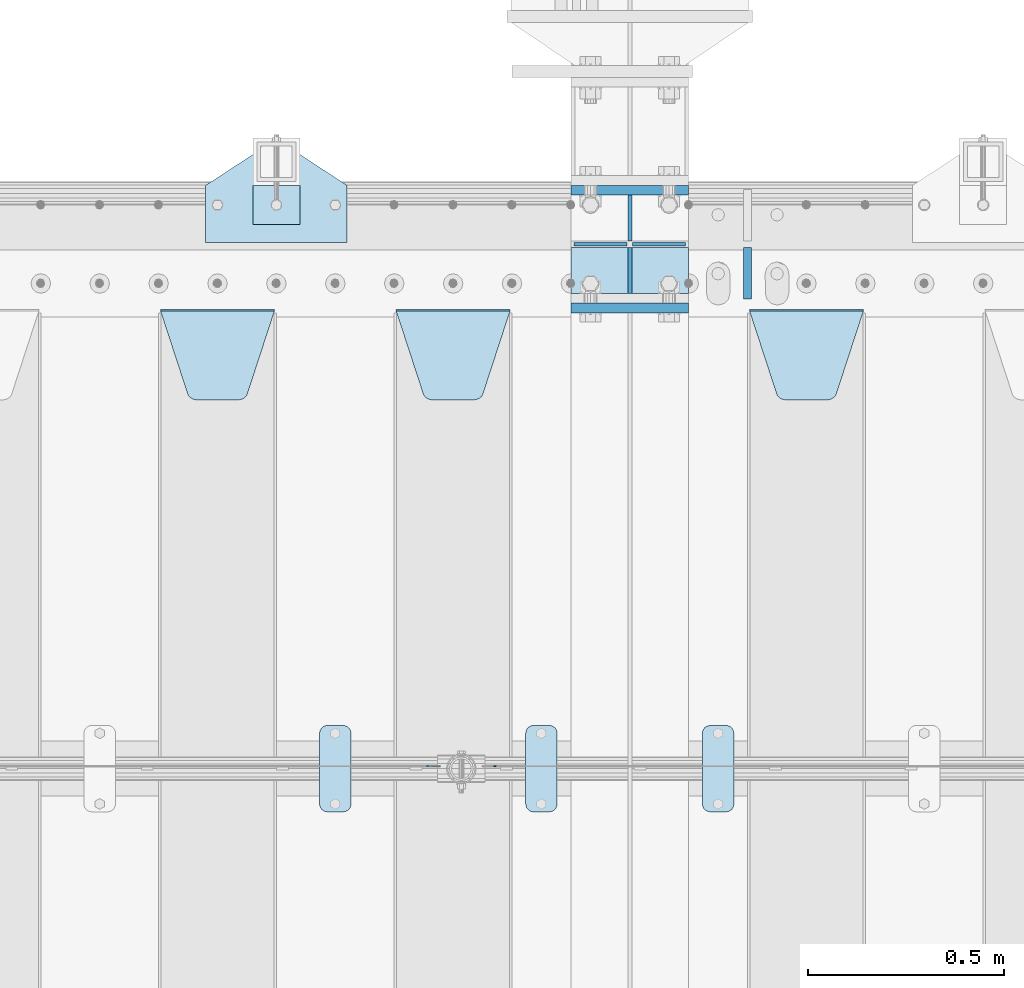
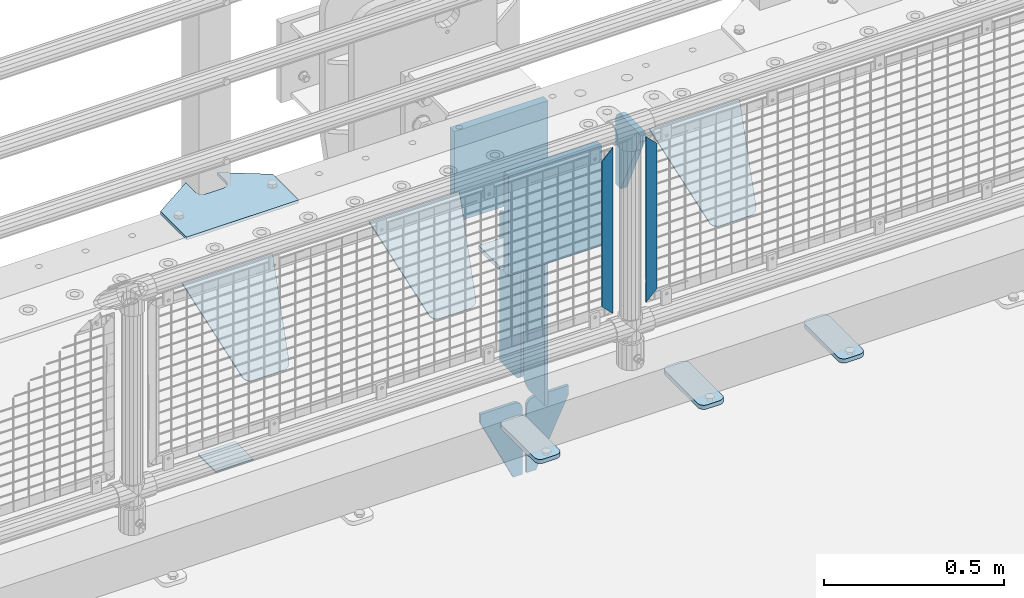
# One storey, part 220 of 247: 18 plates.
"""IFC2X3 building model written with IfcOpenShell, lengths in millimetres."""

import ifcopenshell
import ifcopenshell.guid

model = None  # the IFC model being written
_history = None  # IfcOwnerHistory: only IFC2X3 demands one
_inside = {}  # id of a spatial element -> (the spatial element, [elements in it])
_under = {}  # id of a project, library or spatial element -> (it, [spatial elements below it])
_declared = {}  # id of a project -> (the project, [libraries it declares])
_typed = {}  # id of a type object -> (the type object, [elements of that type])
_made_of = {}  # id of a material, layer set ... -> (it, [elements and type objects made of it])


def new_model(schema):
    """Start an empty IFC model of exactly this schema.

    Asked for "IFC4X3", IfcOpenShell would pick the latest addendum, in which some entities
    have other attributes; the version numbers below select the first issue.
    IFC2X3 requires an IfcOwnerHistory on every rooted entity: one is made here for all.
    """
    global model, _history
    if schema == "IFC4X3":
        model = ifcopenshell.file(schema_version=(4, 3, 0, 0))
    else:
        model = ifcopenshell.file(schema=schema)
    _inside.clear()
    _under.clear()
    _declared.clear()
    _typed.clear()
    _made_of.clear()
    _history = None
    if model.schema == "IFC2X3":
        org = make("IfcOrganization", Name="unknown")
        user = make(
            "IfcPersonAndOrganization",
            ThePerson=make("IfcPerson", FamilyName="unknown"),
            TheOrganization=org,
        )
        app = make(
            "IfcApplication",
            ApplicationDeveloper=org,
            Version="unknown",
            ApplicationFullName="unknown",
            ApplicationIdentifier="unknown",
        )
        _history = make(
            "IfcOwnerHistory",
            OwningUser=user,
            OwningApplication=app,
            ChangeAction="ADDED",
            CreationDate=0,
        )
    return model


def make(cls, **values):
    """One entity of the class cls with the attributes given. An attribute that is None is left unset."""
    return model.create_entity(
        cls, **{name: value for name, value in values.items() if value is not None}
    )


def rooted(cls, **values):
    """An entity with a GlobalId (a new one), such as an element, a storey or a relation."""
    return make(cls, GlobalId=ifcopenshell.guid.new(), OwnerHistory=_history, **values)


def si_unit(unit_type, name, prefix=None):
    """IfcSIUnit, for example si_unit("LENGTHUNIT", "METRE", prefix="MILLI")."""
    return make("IfcSIUnit", UnitType=unit_type, Prefix=prefix, Name=name)


def assignment(units):
    """IfcUnitAssignment: the units of a project."""
    return None if units is None else make("IfcUnitAssignment", Units=units)


def point(xyz):
    """IfcCartesianPoint."""
    return None if xyz is None else make("IfcCartesianPoint", Coordinates=xyz)


def direction(xyz):
    """IfcDirection."""
    return None if xyz is None else make("IfcDirection", DirectionRatios=xyz)


def frame(location, z_axis=None, x_axis=None):
    """IfcAxis2Placement3D, a coordinate frame: its origin and axes. An axis left out is left unset."""
    return make(
        "IfcAxis2Placement3D",
        Location=point(location),
        Axis=direction(z_axis),
        RefDirection=direction(x_axis),
    )


def origin_with_axes():
    """The frame at (0, 0, 0) with the z axis (0, 0, 1) and the x axis (1, 0, 0) written out."""
    return frame((0.0, 0.0, 0.0), z_axis=(0.0, 0.0, 1.0), x_axis=(1.0, 0.0, 0.0))


def place(relative_to, where):
    """IfcLocalPlacement: puts the frame where relative to a parent placement (None: the world)."""
    return make(
        "IfcLocalPlacement", PlacementRelTo=relative_to, RelativePlacement=where
    )


def context(
    kind, dimensions, precision=None, world=None, true_north=None, identifier=None
):
    """IfcGeometricRepresentationContext, for example the 3D "Model" context."""
    return make(
        "IfcGeometricRepresentationContext",
        ContextIdentifier=identifier,
        ContextType=kind,
        CoordinateSpaceDimension=dimensions,
        Precision=precision,
        WorldCoordinateSystem=world,
        TrueNorth=true_north,
    )


def subcontext(parent, identifier, kind, view, scale=None):
    """IfcGeometricRepresentationSubContext, for example "Body" below "Model"."""
    return make(
        "IfcGeometricRepresentationSubContext",
        ContextIdentifier=identifier,
        ContextType=kind,
        ParentContext=parent,
        TargetScale=scale,
        TargetView=view,
    )


def project(units=None, contexts=None):
    """IfcProject with its units and contexts."""
    return rooted(
        "IfcProject",
        Name="project",
        RepresentationContexts=contexts,
        UnitsInContext=assignment(units),
    )


def spatial(cls, under=None, at=None, **own):
    """A site, building, storey or space (cls), placed at a placement, below another one or the project."""
    s = rooted(cls, ObjectPlacement=at, **own)
    if under is not None:
        _under.setdefault(under.id(), (under, []))[1].append(s)
    return s


def faces_of(points, faces, orient=None, outer=None):
    """IfcFace entities. A face is a list of loops; a loop is a list of indices into points, from 0.

    orient and outer hold one flag for each loop. By default every Orientation is true, the
    first loop of a face is its IfcFaceOuterBound and the others are IfcFaceBound.
    """
    made = []
    for i, loops in enumerate(faces):
        bounds = []
        for j, loop in enumerate(loops):
            is_outer = j == 0 if outer is None else outer[i][j]
            bounds.append(
                make(
                    "IfcFaceOuterBound" if is_outer else "IfcFaceBound",
                    Bound=make("IfcPolyLoop", Polygon=[points[k] for k in loop]),
                    Orientation=True if orient is None else orient[i][j],
                )
            )
        made.append(make("IfcFace", Bounds=bounds))
    return made


def faceted_brep(points, faces, orient=None, outer=None, voids=None):
    """IfcFacetedBrep: a solid bounded by flat faces; with voids (closed shells), ...WithVoids."""
    shared = [point(p) for p in points]
    hull = make("IfcClosedShell", CfsFaces=faces_of(shared, faces, orient, outer))
    if voids is None:
        return make("IfcFacetedBrep", Outer=hull)
    return make(
        "IfcFacetedBrepWithVoids",
        Outer=hull,
        Voids=[
            make(cls, CfsFaces=faces_of(shared, fs, o, b)) for cls, fs, o, b in voids
        ],
    )


def shape(context_of_items, identifier, shape_type, items):
    """IfcShapeRepresentation: the items that make up one representation, for example the "Body"."""
    return make(
        "IfcShapeRepresentation",
        ContextOfItems=context_of_items,
        RepresentationIdentifier=identifier,
        RepresentationType=shape_type,
        Items=items,
    )


def material(Name=None, Category=None):
    """IfcMaterial."""
    return make("IfcMaterial", Name=Name, Category=Category)


def made_of(thing, what):
    """Note that an element or type object is made of a material, layer set ...; save() writes the relation."""
    if what is not None:
        _made_of.setdefault(what.id(), (what, []))[1].append(thing)
    return thing


def type_object(cls, material=None, **own):
    """A type object (cls), such as IfcWallType, which elements share."""
    return made_of(rooted(cls, **own), material)


def element(
    cls,
    number,
    at=None,
    inside=None,
    cuts=None,
    type_object=None,
    material=None,
    context=None,
    identifier="Body",
    shape_type=None,
    held_by="IfcProductDefinitionShape",
    body=None,
    shapes=None,
    **own,
):
    """One element of the class cls, such as IfcWall. Its Tag is "e" and its number.

    at: its placement. inside: the storey or other place that contains it. cuts: it is an
    opening in that element (IfcRelVoidsElement). A single representation is given by context,
    identifier, shape_type and body (its items); several are given by shapes. held_by: the class
    of the entity that holds the representations. save() writes the other relations.
    """
    e = rooted(cls, Tag="e%d" % number, ObjectPlacement=at, **own)
    if body is not None:
        shapes = [shape(context, identifier, shape_type, body)]
    if shapes is not None:
        e.Representation = make(held_by, Representations=shapes)
    if inside is not None:
        _inside.setdefault(inside.id(), (inside, []))[1].append(e)
    if cuts is not None:
        rooted(
            "IfcRelVoidsElement", RelatingBuildingElement=cuts, RelatedOpeningElement=e
        )
    if type_object is not None:
        _typed.setdefault(type_object.id(), (type_object, []))[1].append(e)
    return made_of(e, material)


def aggregate(whole, parts):
    """IfcRelAggregates: a whole, such as a stair, and the parts it consists of."""
    return rooted("IfcRelAggregates", RelatingObject=whole, RelatedObjects=parts)


def save(model, path):
    """Write the relations noted so far, then the file.

    IfcRelAggregates (storeys below a building ...), IfcRelContainedInSpatialStructure (elements
    in a storey), IfcRelDefinesByType, IfcRelAssociatesMaterial and IfcRelDeclares: one each for
    every whole, place, type object, material and project.
    """
    for whole, parts in _under.values():
        aggregate(whole, parts)
    for where, things in _inside.values():
        rooted(
            "IfcRelContainedInSpatialStructure",
            RelatedElements=things,
            RelatingStructure=where,
        )
    for kind, things in _typed.values():
        rooted("IfcRelDefinesByType", RelatedObjects=things, RelatingType=kind)
    for what, things in _made_of.values():
        rooted("IfcRelAssociatesMaterial", RelatedObjects=things, RelatingMaterial=what)
    for by, libraries in _declared.values():
        rooted("IfcRelDeclares", RelatingContext=by, RelatedDefinitions=libraries)
    model.write(path)


model = new_model("IFC2X3")

# Units and contexts
model_context = context("Model", 3, precision=1e-05, world=origin_with_axes())
body_context = subcontext(model_context, "Body", "Model", "MODEL_VIEW")
ifc_project = project(units=[si_unit("LENGTHUNIT", "METRE", prefix="MILLI"), si_unit("AREAUNIT", "SQUARE_METRE"), si_unit("VOLUMEUNIT", "CUBIC_METRE"), si_unit("MASSUNIT", "GRAM", prefix="KILO"), si_unit("TIMEUNIT", "SECOND"), si_unit("PLANEANGLEUNIT", "RADIAN"), si_unit("SOLIDANGLEUNIT", "STERADIAN"), si_unit("THERMODYNAMICTEMPERATUREUNIT", "DEGREE_CELSIUS"), si_unit("LUMINOUSINTENSITYUNIT", "LUMEN")], contexts=[model_context])

# Site, building, storey
site_placement = place(None, origin_with_axes())
site = spatial("IfcSite", under=ifc_project, at=site_placement, CompositionType="ELEMENT")
building_placement = place(site_placement, origin_with_axes())
building = spatial("IfcBuilding", under=site, at=building_placement, Name="Standard", CompositionType="ELEMENT")
storey_placement = place(building_placement, origin_with_axes())
storey = spatial("IfcBuildingStorey", under=building, at=storey_placement, Name="Undefined", CompositionType="ELEMENT", Elevation=0.0)

# Plates
ifc_material_1 = material(Name="STEEL/S355N")
plate_type_1 = type_object("IfcPlateType", PredefinedType="NOTDEFINED")
plate_1_placement = place(storey_placement, frame((12100.0, 8837.5, -340.000000000044), z_axis=(0.0, 0.0, 1.0), x_axis=(1.0, 0.0, 0.0)))
element("IfcPlate", 1, at=plate_1_placement, inside=storey, type_object=plate_type_1, material=ifc_material_1, context=body_context, shape_type="Brep", body=[
    faceted_brep([(0.0, -12.5, 0.0), (0.0, -12.5, 340.0), (0.0, 12.5, 340.0), (0.0, 12.5, 0.0), (300.0, -12.5, 340.0), (300.0, 12.5, 340.0), (300.0, -12.5, 0.0), (300.0, 12.5, 0.0)], [[[0, 1, 2, 3]], [[1, 4, 5, 2]], [[4, 6, 7, 5]], [[6, 0, 3, 7]], [[5, 7, 3, 2]], [[6, 4, 1, 0]]]),
])
plate_2_placement = place(storey_placement, frame((12100.0, 9137.5, -340.0), z_axis=(0.0, 0.0, 1.0), x_axis=(1.0, 0.0, 0.0)))
element("IfcPlate", 2, at=plate_2_placement, inside=storey, type_object=plate_type_1, material=ifc_material_1, context=body_context, shape_type="Brep", body=[
    faceted_brep([(0.0, -12.5, 0.0), (0.0, -12.5, 310.0), (0.0, 12.5, 310.0), (0.0, 12.5, 0.0), (300.0, -12.5, 310.0), (300.0, 12.5, 310.0), (300.0, -12.5, 0.0), (300.0, 12.5, 0.0)], [[[0, 1, 2, 3]], [[1, 4, 5, 2]], [[4, 6, 7, 5]], [[6, 0, 3, 7]], [[5, 7, 3, 2]], [[6, 4, 1, 0]]]),
])
plate_type_2 = type_object("IfcPlateType", PredefinedType="NOTDEFINED")
plate_3_placement = place(storey_placement, frame((12100.0, 8992.0, -343.0), z_axis=(0.0, -0.999999999999548, -9.5100000000016e-07), x_axis=(1.0, 0.0, 0.0)))
element("IfcPlate", 3, at=plate_3_placement, inside=storey, type_object=plate_type_2, material=ifc_material_1, context=body_context, shape_type="Brep", body=[
    faceted_brep([(0.0, -7.0, 0.0), (0.0, -7.0, 117.0), (0.0, 7.0, 117.0), (0.0, 7.0, 0.0), (300.0, -7.0, 117.0), (300.0, 7.0, 117.0), (300.0, -7.0, 0.0), (300.0, 7.0, 0.0)], [[[0, 1, 2, 3]], [[1, 4, 5, 2]], [[4, 6, 7, 5]], [[6, 0, 3, 7]], [[5, 7, 3, 2]], [[6, 4, 1, 0]]]),
])
plate_type_3 = type_object("IfcPlateType", PredefinedType="NOTDEFINED")
for number, where, z_axis, x_axis in (
    (4, (12250.0, 8992.0, -350.0), (0.0, 0.0, -1.0), (0.0, -0.999999999999548, -9.5100000000016e-07)),
    (5, (12250.0, 9008.0, -350.0), (0.0, 0.0, -1.0), (0.0, 1.0, 0.0)),
):
    element("IfcPlate", number, at=place(storey_placement, frame(where, z_axis=z_axis, x_axis=x_axis)), inside=storey, type_object=plate_type_3, material=ifc_material_1, context=body_context, shape_type="Brep", body=[
        faceted_brep([(9.04219632502645e-09, -5.00000000143385, -2.89173840428703e-09), (0.0, -5.0, 480.0), (0.0, 5.0, 480.0), (7.66340235713869e-09, 4.99999999856618, -2.89173840428703e-09), (0.455767409633609, -5.0, 485.209445330008), (0.455767409633609, 5.0, 485.209445330008), (1.80922137642256, -5.0, 490.26060429977), (1.80922137642256, 5.0, 490.26060429977), (4.01923788646673, -5.0, 495.0), (4.01923788646673, 5.0, 495.0), (7.01866670643085, -5.0, 499.283628290596), (7.01866670643085, 5.0, 499.283628290596), (10.716371709404, -5.0, 502.981333293569), (10.716371709404, 5.0, 502.981333293569), (15.0, -5.0, 505.980762113533), (15.0, 5.0, 505.980762113533), (19.73939570023, -5.0, 508.190778623577), (19.73939570023, 5.0, 508.190778623577), (24.7905546699922, -5.0, 509.544232590366), (24.7905546699922, 5.0, 509.544232590366), (30.0, -5.0, 510.0), (30.0, 5.0, 510.0), (117.0, -5.0, 510.0), (117.0, 5.0, 510.0), (117.0, -5.0, 0.0), (117.0, 5.0, 0.0)], [[[0, 1, 2, 3]], [[1, 4, 5, 2]], [[4, 6, 7, 5]], [[6, 8, 9, 7]], [[8, 10, 11, 9]], [[10, 12, 13, 11]], [[12, 14, 15, 13]], [[14, 16, 17, 15]], [[16, 18, 19, 17]], [[18, 20, 21, 19]], [[20, 22, 23, 21]], [[22, 24, 25, 23]], [[24, 0, 3, 25]], [[5, 7, 9, 11, 13, 15, 17, 19, 21, 23, 25, 3, 2]], [[24, 22, 20, 18, 16, 14, 12, 10, 8, 6, 4, 1, 0]]]),
    ])
ifc_material_2 = material(Name="STEEL/S355J2")
plate_type_4 = type_object("IfcPlateType", PredefinedType="NOTDEFINED")
plate_4_placement = place(storey_placement, frame((11985.0, 7774.5, 21.0199999999977), z_axis=(1.0, 0.0, 0.0), x_axis=(0.0, -0.999999999999548, -9.5100000000016e-07)))
element("IfcPlate", 6, at=plate_4_placement, inside=storey, type_object=plate_type_4, material=ifc_material_2, context=body_context, shape_type="Brep", body=[
    faceted_brep([(0.0, -7.0, 20.0), (0.0, -7.0, 60.0), (0.0, 7.0, 60.0), (0.0, 7.0, 20.0), (0.384294391935327, -7.0, 63.9018064403226), (0.384294391935327, 7.0, 63.9018064403226), (1.52240934977453, -7.0, 67.6536686473009), (1.52240934977453, 7.0, 67.6536686473009), (3.37060775394912, -7.0, 71.1114046603925), (3.37060775394912, 7.0, 71.1114046603925), (5.85786437626939, -7.0, 74.1421356237315), (5.85786437626939, 7.0, 74.1421356237315), (8.8885953396084, -7.0, 76.6293922460518), (8.8885953396084, 7.0, 76.6293922460518), (12.3463313526981, -7.0, 78.4775906502255), (12.3463313526981, 7.0, 78.4775906502255), (16.0981935596774, -7.0, 79.6157056080647), (16.0981935596774, 7.0, 79.6157056080647), (20.0, -7.0, 80.0), (20.0, 7.0, 80.0), (200.0, -7.0, 80.0), (200.0, 7.0, 80.0), (203.901806440323, -7.0, 79.6157056080647), (203.901806440323, 7.0, 79.6157056080647), (207.653668647302, -7.0, 78.4775906502255), (207.653668647302, 7.0, 78.4775906502255), (211.111404660392, -7.0, 76.6293922460518), (211.111404660392, 7.0, 76.6293922460518), (214.142135623731, -7.0, 74.1421356237315), (214.142135623731, 7.0, 74.1421356237315), (216.629392246051, -7.0, 71.1114046603925), (216.629392246051, 7.0, 71.1114046603925), (218.477590650225, -7.0, 67.6536686473009), (218.477590650225, 7.0, 67.6536686473009), (219.615705608065, -7.0, 63.9018064403226), (219.615705608065, 7.0, 63.9018064403226), (220.0, -7.0, 60.0), (220.0, 7.0, 60.0), (220.0, -7.0, 20.0), (220.0, 7.0, 20.0), (219.615705608065, -7.0, 16.0981935596774), (219.615705608065, 7.0, 16.0981935596774), (218.477590650225, -7.0, 12.3463313526991), (218.477590650225, 7.0, 12.3463313526991), (216.629392246051, -7.0, 8.88859533960749), (216.629392246051, 7.0, 8.88859533960749), (214.142135623731, -7.0, 5.85786437626848), (214.142135623731, 7.0, 5.85786437626848), (211.111404660392, -7.0, 3.37060775394821), (211.111404660392, 7.0, 3.37060775394821), (207.653668647302, -7.0, 1.52240934977453), (207.653668647302, 7.0, 1.52240934977453), (203.901806440323, -7.0, 0.384294391935327), (203.901806440323, 7.0, 0.384294391935327), (200.0, -7.0, 0.0), (200.0, 7.0, 0.0), (20.0, -7.0, 0.0), (20.0, 7.0, 0.0), (16.0981935596774, -7.0, 0.384294391935327), (16.0981935596774, 7.0, 0.384294391935327), (12.3463313526981, -7.0, 1.52240934977453), (12.3463313526981, 7.0, 1.52240934977453), (8.8885953396084, -7.0, 3.37060775394821), (8.8885953396084, 7.0, 3.37060775394821), (5.85786437626939, -7.0, 5.85786437626848), (5.85786437626939, 7.0, 5.85786437626848), (3.37060775394912, -7.0, 8.88859533960749), (3.37060775394912, 7.0, 8.88859533960749), (1.52240934977453, -7.0, 12.3463313526991), (1.52240934977453, 7.0, 12.3463313526991), (0.384294391935327, -7.0, 16.0981935596774), (0.384294391935327, 7.0, 16.0981935596774)], [[[0, 1, 2, 3]], [[1, 4, 5, 2]], [[4, 6, 7, 5]], [[6, 8, 9, 7]], [[8, 10, 11, 9]], [[10, 12, 13, 11]], [[12, 14, 15, 13]], [[14, 16, 17, 15]], [[16, 18, 19, 17]], [[18, 20, 21, 19]], [[20, 22, 23, 21]], [[22, 24, 25, 23]], [[24, 26, 27, 25]], [[26, 28, 29, 27]], [[28, 30, 31, 29]], [[30, 32, 33, 31]], [[32, 34, 35, 33]], [[34, 36, 37, 35]], [[36, 38, 39, 37]], [[38, 40, 41, 39]], [[40, 42, 43, 41]], [[42, 44, 45, 43]], [[44, 46, 47, 45]], [[46, 48, 49, 47]], [[48, 50, 51, 49]], [[50, 52, 53, 51]], [[52, 54, 55, 53]], [[54, 56, 57, 55]], [[56, 58, 59, 57]], [[58, 60, 61, 59]], [[60, 62, 63, 61]], [[62, 64, 65, 63]], [[64, 66, 67, 65]], [[66, 68, 69, 67]], [[68, 70, 71, 69]], [[70, 0, 3, 71]], [[5, 7, 9, 11, 13, 15, 17, 19, 21, 23, 25, 27, 29, 31, 33, 35, 37, 39, 41, 43, 45, 47, 49, 51, 53, 55, 57, 59, 61, 63, 65, 67, 69, 71, 3, 2]], [[70, 68, 66, 64, 62, 60, 58, 56, 54, 52, 50, 48, 46, 44, 42, 40, 38, 36, 34, 32, 30, 28, 26, 24, 22, 20, 18, 16, 14, 12, 10, 8, 6, 4, 1, 0]]]),
])
plate_5_placement = place(storey_placement, frame((11460.0, 7774.5, 21.0199999999977), z_axis=(1.0, 0.0, 0.0), x_axis=(0.0, -0.999999999999548, -9.5100000000016e-07)))
element("IfcPlate", 7, at=plate_5_placement, inside=storey, type_object=plate_type_4, material=ifc_material_2, context=body_context, shape_type="Brep", body=[
    faceted_brep([(0.0, -7.0, 20.0), (0.0, -7.0, 60.0), (0.0, 7.0, 60.0), (0.0, 7.0, 20.0), (0.384294391935327, -7.0, 63.9018064403226), (0.384294391935327, 7.0, 63.9018064403226), (1.52240934977453, -7.0, 67.6536686473009), (1.52240934977453, 7.0, 67.6536686473009), (3.37060775394912, -7.0, 71.1114046603925), (3.37060775394912, 7.0, 71.1114046603925), (5.85786437626939, -7.0, 74.1421356237315), (5.85786437626939, 7.0, 74.1421356237315), (8.8885953396084, -7.0, 76.6293922460518), (8.8885953396084, 7.0, 76.6293922460518), (12.3463313526981, -7.0, 78.4775906502255), (12.3463313526981, 7.0, 78.4775906502255), (16.0981935596774, -7.0, 79.6157056080647), (16.0981935596774, 7.0, 79.6157056080647), (20.0, -7.0, 80.0), (20.0, 7.0, 80.0), (200.0, -7.0, 80.0), (200.0, 7.0, 80.0), (203.901806440323, -7.0, 79.6157056080647), (203.901806440323, 7.0, 79.6157056080647), (207.653668647302, -7.0, 78.4775906502255), (207.653668647302, 7.0, 78.4775906502255), (211.111404660392, -7.0, 76.6293922460518), (211.111404660392, 7.0, 76.6293922460518), (214.142135623731, -7.0, 74.1421356237315), (214.142135623731, 7.0, 74.1421356237315), (216.629392246051, -7.0, 71.1114046603925), (216.629392246051, 7.0, 71.1114046603925), (218.477590650225, -7.0, 67.6536686473009), (218.477590650225, 7.0, 67.6536686473009), (219.615705608065, -7.0, 63.9018064403226), (219.615705608065, 7.0, 63.9018064403226), (220.0, -7.0, 60.0), (220.0, 7.0, 60.0), (220.0, -7.0, 20.0), (220.0, 7.0, 20.0), (219.615705608065, -7.0, 16.0981935596774), (219.615705608065, 7.0, 16.0981935596774), (218.477590650225, -7.0, 12.3463313526991), (218.477590650225, 7.0, 12.3463313526991), (216.629392246051, -7.0, 8.88859533960749), (216.629392246051, 7.0, 8.88859533960749), (214.142135623731, -7.0, 5.85786437626848), (214.142135623731, 7.0, 5.85786437626848), (211.111404660392, -7.0, 3.37060775394821), (211.111404660392, 7.0, 3.37060775394821), (207.653668647302, -7.0, 1.52240934977453), (207.653668647302, 7.0, 1.52240934977453), (203.901806440323, -7.0, 0.384294391935327), (203.901806440323, 7.0, 0.384294391935327), (200.0, -7.0, 0.0), (200.0, 7.0, 0.0), (20.0, -7.0, 0.0), (20.0, 7.0, 0.0), (16.0981935596774, -7.0, 0.384294391935327), (16.0981935596774, 7.0, 0.384294391935327), (12.3463313526981, -7.0, 1.52240934977453), (12.3463313526981, 7.0, 1.52240934977453), (8.8885953396084, -7.0, 3.37060775394821), (8.8885953396084, 7.0, 3.37060775394821), (5.85786437626939, -7.0, 5.85786437626848), (5.85786437626939, 7.0, 5.85786437626848), (3.37060775394912, -7.0, 8.88859533960749), (3.37060775394912, 7.0, 8.88859533960749), (1.52240934977453, -7.0, 12.3463313526991), (1.52240934977453, 7.0, 12.3463313526991), (0.384294391935327, -7.0, 16.0981935596774), (0.384294391935327, 7.0, 16.0981935596774)], [[[0, 1, 2, 3]], [[1, 4, 5, 2]], [[4, 6, 7, 5]], [[6, 8, 9, 7]], [[8, 10, 11, 9]], [[10, 12, 13, 11]], [[12, 14, 15, 13]], [[14, 16, 17, 15]], [[16, 18, 19, 17]], [[18, 20, 21, 19]], [[20, 22, 23, 21]], [[22, 24, 25, 23]], [[24, 26, 27, 25]], [[26, 28, 29, 27]], [[28, 30, 31, 29]], [[30, 32, 33, 31]], [[32, 34, 35, 33]], [[34, 36, 37, 35]], [[36, 38, 39, 37]], [[38, 40, 41, 39]], [[40, 42, 43, 41]], [[42, 44, 45, 43]], [[44, 46, 47, 45]], [[46, 48, 49, 47]], [[48, 50, 51, 49]], [[50, 52, 53, 51]], [[52, 54, 55, 53]], [[54, 56, 57, 55]], [[56, 58, 59, 57]], [[58, 60, 61, 59]], [[60, 62, 63, 61]], [[62, 64, 65, 63]], [[64, 66, 67, 65]], [[66, 68, 69, 67]], [[68, 70, 71, 69]], [[70, 0, 3, 71]], [[5, 7, 9, 11, 13, 15, 17, 19, 21, 23, 25, 27, 29, 31, 33, 35, 37, 39, 41, 43, 45, 47, 49, 51, 53, 55, 57, 59, 61, 63, 65, 67, 69, 71, 3, 2]], [[70, 68, 66, 64, 62, 60, 58, 56, 54, 52, 50, 48, 46, 44, 42, 40, 38, 36, 34, 32, 30, 28, 26, 24, 22, 20, 18, 16, 14, 12, 10, 8, 6, 4, 1, 0]]]),
])
plate_6_placement = place(storey_placement, frame((12435.0, 7774.5, 21.0199999999977), z_axis=(1.0, 0.0, 0.0), x_axis=(0.0, -0.999999999999548, -9.5100000000016e-07)))
element("IfcPlate", 8, at=plate_6_placement, inside=storey, type_object=plate_type_4, material=ifc_material_2, context=body_context, shape_type="Brep", body=[
    faceted_brep([(0.0, -7.0, 20.0), (0.0, -7.0, 60.0), (0.0, 7.0, 60.0), (0.0, 7.0, 20.0), (0.384294391935327, -7.0, 63.9018064403226), (0.384294391935327, 7.0, 63.9018064403226), (1.52240934977453, -7.0, 67.6536686473009), (1.52240934977453, 7.0, 67.6536686473009), (3.37060775394912, -7.0, 71.1114046603925), (3.37060775394912, 7.0, 71.1114046603925), (5.85786437626939, -7.0, 74.1421356237315), (5.85786437626939, 7.0, 74.1421356237315), (8.8885953396084, -7.0, 76.6293922460518), (8.8885953396084, 7.0, 76.6293922460518), (12.3463313526981, -7.0, 78.4775906502255), (12.3463313526981, 7.0, 78.4775906502255), (16.0981935596774, -7.0, 79.6157056080647), (16.0981935596774, 7.0, 79.6157056080647), (20.0, -7.0, 80.0), (20.0, 7.0, 80.0), (200.0, -7.0, 80.0), (200.0, 7.0, 80.0), (203.901806440323, -7.0, 79.6157056080647), (203.901806440323, 7.0, 79.6157056080647), (207.653668647302, -7.0, 78.4775906502255), (207.653668647302, 7.0, 78.4775906502255), (211.111404660392, -7.0, 76.6293922460518), (211.111404660392, 7.0, 76.6293922460518), (214.142135623731, -7.0, 74.1421356237315), (214.142135623731, 7.0, 74.1421356237315), (216.629392246051, -7.0, 71.1114046603925), (216.629392246051, 7.0, 71.1114046603925), (218.477590650225, -7.0, 67.6536686473009), (218.477590650225, 7.0, 67.6536686473009), (219.615705608065, -7.0, 63.9018064403226), (219.615705608065, 7.0, 63.9018064403226), (220.0, -7.0, 60.0), (220.0, 7.0, 60.0), (220.0, -7.0, 20.0), (220.0, 7.0, 20.0), (219.615705608065, -7.0, 16.0981935596774), (219.615705608065, 7.0, 16.0981935596774), (218.477590650225, -7.0, 12.3463313526991), (218.477590650225, 7.0, 12.3463313526991), (216.629392246051, -7.0, 8.88859533960749), (216.629392246051, 7.0, 8.88859533960749), (214.142135623731, -7.0, 5.85786437626848), (214.142135623731, 7.0, 5.85786437626848), (211.111404660392, -7.0, 3.37060775394821), (211.111404660392, 7.0, 3.37060775394821), (207.653668647302, -7.0, 1.52240934977453), (207.653668647302, 7.0, 1.52240934977453), (203.901806440323, -7.0, 0.384294391935327), (203.901806440323, 7.0, 0.384294391935327), (200.0, -7.0, 0.0), (200.0, 7.0, 0.0), (20.0, -7.0, 0.0), (20.0, 7.0, 0.0), (16.0981935596774, -7.0, 0.384294391935327), (16.0981935596774, 7.0, 0.384294391935327), (12.3463313526981, -7.0, 1.52240934977453), (12.3463313526981, 7.0, 1.52240934977453), (8.8885953396084, -7.0, 3.37060775394821), (8.8885953396084, 7.0, 3.37060775394821), (5.85786437626939, -7.0, 5.85786437626848), (5.85786437626939, 7.0, 5.85786437626848), (3.37060775394912, -7.0, 8.88859533960749), (3.37060775394912, 7.0, 8.88859533960749), (1.52240934977453, -7.0, 12.3463313526991), (1.52240934977453, 7.0, 12.3463313526991), (0.384294391935327, -7.0, 16.0981935596774), (0.384294391935327, 7.0, 16.0981935596774)], [[[0, 1, 2, 3]], [[1, 4, 5, 2]], [[4, 6, 7, 5]], [[6, 8, 9, 7]], [[8, 10, 11, 9]], [[10, 12, 13, 11]], [[12, 14, 15, 13]], [[14, 16, 17, 15]], [[16, 18, 19, 17]], [[18, 20, 21, 19]], [[20, 22, 23, 21]], [[22, 24, 25, 23]], [[24, 26, 27, 25]], [[26, 28, 29, 27]], [[28, 30, 31, 29]], [[30, 32, 33, 31]], [[32, 34, 35, 33]], [[34, 36, 37, 35]], [[36, 38, 39, 37]], [[38, 40, 41, 39]], [[40, 42, 43, 41]], [[42, 44, 45, 43]], [[44, 46, 47, 45]], [[46, 48, 49, 47]], [[48, 50, 51, 49]], [[50, 52, 53, 51]], [[52, 54, 55, 53]], [[54, 56, 57, 55]], [[56, 58, 59, 57]], [[58, 60, 61, 59]], [[60, 62, 63, 61]], [[62, 64, 65, 63]], [[64, 66, 67, 65]], [[66, 68, 69, 67]], [[68, 70, 71, 69]], [[70, 0, 3, 71]], [[5, 7, 9, 11, 13, 15, 17, 19, 21, 23, 25, 27, 29, 31, 33, 35, 37, 39, 41, 43, 45, 47, 49, 51, 53, 55, 57, 59, 61, 63, 65, 67, 69, 71, 3, 2]], [[70, 68, 66, 64, 62, 60, 58, 56, 54, 52, 50, 48, 46, 44, 42, 40, 38, 36, 34, 32, 30, 28, 26, 24, 22, 20, 18, 16, 14, 12, 10, 8, 6, 4, 1, 0]]]),
])
plate_type_5 = type_object("IfcPlateType", PredefinedType="NOTDEFINED")
for number, where, z_axis, x_axis in (
    (9, (12243.5000000106, 8999.99999998465, -915.000018222568), (0.0, 0.0, -1.0), (-1.0, 0.0, 0.0)),
    (10, (12256.5000000107, 8999.99999998464, -915.000018222568), (0.0, 0.0, -1.0), (1.0, 0.0, 0.0)),
):
    element("IfcPlate", number, at=place(storey_placement, frame(where, z_axis=z_axis, x_axis=x_axis)), inside=storey, type_object=plate_type_5, material=ifc_material_1, context=body_context, shape_type="Brep", body=[
        faceted_brep([(0.0, -5.0, 27.0), (0.0, -5.0, 250.0), (0.0, 5.0, 250.0), (0.0, 5.0, 27.0), (30.0, -5.0, 250.0), (30.0, 5.0, 250.0), (135.0, -5.0, 30.0), (135.0, 5.0, 30.0), (135.0, -5.0, 0.0), (135.0, 5.0, 0.0), (27.0, -5.0, 0.0), (27.0, 5.0, 0.0), (22.3114992029932, -5.0, 0.410190668670339), (22.3114992029932, 5.0, 0.410190668670339), (17.7654561302061, -5.0, 1.62829923878041), (17.7654561302061, 5.0, 1.62829923878041), (13.5, -5.0, 3.61731409782021), (13.5, 5.0, 3.61731409782021), (9.64473453846404, -5.0, 6.31680003578765), (9.64473453846404, 5.0, 6.31680003578765), (6.31680003578731, -5.0, 9.64473453846347), (6.31680003578731, 5.0, 9.64473453846347), (3.61731409782078, -5.0, 13.5), (3.61731409782078, 5.0, 13.5), (1.62829923878053, -5.0, 17.765456130207), (1.62829923878053, 5.0, 17.765456130207), (0.410190668670111, -5.0, 22.3114992029929), (0.410190668670111, 5.0, 22.3114992029929)], [[[0, 1, 2, 3]], [[1, 4, 5, 2]], [[4, 6, 7, 5]], [[6, 8, 9, 7]], [[8, 10, 11, 9]], [[10, 12, 13, 11]], [[12, 14, 15, 13]], [[14, 16, 17, 15]], [[16, 18, 19, 17]], [[18, 20, 21, 19]], [[20, 22, 23, 21]], [[22, 24, 25, 23]], [[24, 26, 27, 25]], [[26, 0, 3, 27]], [[5, 7, 9, 11, 13, 15, 17, 19, 21, 23, 25, 27, 3, 2]], [[26, 24, 22, 20, 18, 16, 14, 12, 10, 8, 6, 4, 1, 0]]]),
    ])
plate_type_6 = type_object("IfcPlateType", PredefinedType="NOTDEFINED")
plate_7_placement = place(storey_placement, frame((12555.0, 8831.76776695594, -1.767766952965), z_axis=(0.0, -0.707106781186548, -0.707106781186547), x_axis=(1.0, 0.0, 0.0)))
element("IfcPlate", 11, at=plate_7_placement, inside=storey, type_object=plate_type_6, material=ifc_material_1, context=body_context, shape_type="Brep", body=[
    faceted_brep([(0.0, -2.49999999999909, 0.0), (69.345504679477, -2.5, 300.17173142483), (69.345504679477, 2.50000000000091, 300.171731424831), (0.0, 2.5, -9.09494701772928e-13), (70.9274061199576, -2.5, 304.897442415399), (70.9274061199576, 2.50000000000091, 304.8974424154), (73.3818627772307, -2.49999999999909, 309.234538108527), (73.3818627772307, 2.5, 309.234538108526), (76.6187032999551, -2.5, 313.023683126102), (76.6187032999551, 2.50000000000091, 313.023683126102), (80.5190132704993, -2.49999999999909, 316.125672595371), (80.5190132704993, 2.50000000000091, 316.125672595372), (84.9395038596849, -2.49999999999909, 318.426546230476), (84.9395038596849, 2.5, 318.426546230475), (89.7177759439219, -2.5, 319.841774983274), (89.7177759439219, 2.50000000000091, 319.841774983275), (94.678286292652, -2.5, 320.319366455077), (94.678286292652, 2.50000000000091, 320.319366455077), (195.321713707348, -2.5, 320.319366455077), (195.321713707348, 2.50000000000091, 320.319366455077), (200.282224056078, -2.5, 319.841774983274), (200.282224056078, 2.50000000000091, 319.841774983275), (205.060496140315, -2.5, 318.426546230475), (205.060496140315, 2.5, 318.426546230474), (209.480986729501, -2.49999999999818, 316.12567259537), (209.480986729501, 2.50000000000091, 316.12567259537), (213.381296700045, -2.5, 313.023683126101), (213.381296700045, 2.50000000000091, 313.023683126101), (216.618137222769, -2.5, 309.234538108525), (216.618137222769, 2.5, 309.234538108525), (219.072593880042, -2.49999999999909, 304.897442415398), (219.072593880042, 2.5, 304.897442415398), (220.654495320523, -2.5, 300.17173142483), (220.654495320523, 2.50000000000091, 300.171731424831), (290.0, -2.49999999999909, 0.0), (290.0, 2.5, -9.09494701772928e-13)], [[[0, 1, 2, 3]], [[1, 4, 5, 2]], [[4, 6, 7, 5]], [[6, 8, 9, 7]], [[8, 10, 11, 9]], [[10, 12, 13, 11]], [[12, 14, 15, 13]], [[14, 16, 17, 15]], [[16, 18, 19, 17]], [[18, 20, 21, 19]], [[20, 22, 23, 21]], [[22, 24, 25, 23]], [[24, 26, 27, 25]], [[26, 28, 29, 27]], [[28, 30, 31, 29]], [[30, 32, 33, 31]], [[32, 34, 35, 33]], [[34, 0, 3, 35]], [[5, 7, 9, 11, 13, 15, 17, 19, 21, 23, 25, 27, 29, 31, 33, 35, 3, 2]], [[34, 32, 30, 28, 26, 24, 22, 20, 18, 16, 14, 12, 10, 8, 6, 4, 1, 0]]]),
])
plate_8_placement = place(storey_placement, frame((11655.0, 8831.76776695594, -1.767766952965), z_axis=(0.0, -0.707106781186548, -0.707106781186547), x_axis=(1.0, 0.0, 0.0)))
element("IfcPlate", 12, at=plate_8_placement, inside=storey, type_object=plate_type_6, material=ifc_material_1, context=body_context, shape_type="Brep", body=[
    faceted_brep([(0.0, -2.49999999999909, 0.0), (69.345504679477, -2.5, 300.17173142483), (69.345504679477, 2.50000000000091, 300.171731424831), (0.0, 2.5, -9.09494701772928e-13), (70.9274061199576, -2.5, 304.897442415399), (70.9274061199576, 2.50000000000091, 304.8974424154), (73.3818627772307, -2.49999999999909, 309.234538108527), (73.3818627772307, 2.5, 309.234538108526), (76.6187032999551, -2.5, 313.023683126102), (76.6187032999551, 2.50000000000091, 313.023683126102), (80.5190132704993, -2.49999999999909, 316.125672595371), (80.5190132704993, 2.50000000000091, 316.125672595372), (84.9395038596849, -2.49999999999909, 318.426546230476), (84.9395038596849, 2.5, 318.426546230475), (89.7177759439219, -2.5, 319.841774983274), (89.7177759439219, 2.50000000000091, 319.841774983275), (94.678286292652, -2.5, 320.319366455077), (94.678286292652, 2.50000000000091, 320.319366455077), (195.321713707348, -2.5, 320.319366455077), (195.321713707348, 2.50000000000091, 320.319366455077), (200.282224056078, -2.5, 319.841774983274), (200.282224056078, 2.50000000000091, 319.841774983275), (205.060496140315, -2.5, 318.426546230475), (205.060496140315, 2.5, 318.426546230474), (209.480986729501, -2.49999999999818, 316.12567259537), (209.480986729501, 2.50000000000091, 316.12567259537), (213.381296700045, -2.5, 313.023683126101), (213.381296700045, 2.50000000000091, 313.023683126101), (216.618137222769, -2.5, 309.234538108525), (216.618137222769, 2.5, 309.234538108525), (219.072593880042, -2.49999999999909, 304.897442415398), (219.072593880042, 2.5, 304.897442415398), (220.654495320523, -2.5, 300.17173142483), (220.654495320523, 2.50000000000091, 300.171731424831), (290.0, -2.49999999999909, 0.0), (290.0, 2.5, -9.09494701772928e-13)], [[[0, 1, 2, 3]], [[1, 4, 5, 2]], [[4, 6, 7, 5]], [[6, 8, 9, 7]], [[8, 10, 11, 9]], [[10, 12, 13, 11]], [[12, 14, 15, 13]], [[14, 16, 17, 15]], [[16, 18, 19, 17]], [[18, 20, 21, 19]], [[20, 22, 23, 21]], [[22, 24, 25, 23]], [[24, 26, 27, 25]], [[26, 28, 29, 27]], [[28, 30, 31, 29]], [[30, 32, 33, 31]], [[32, 34, 35, 33]], [[34, 0, 3, 35]], [[5, 7, 9, 11, 13, 15, 17, 19, 21, 23, 25, 27, 29, 31, 33, 35, 3, 2]], [[34, 32, 30, 28, 26, 24, 22, 20, 18, 16, 14, 12, 10, 8, 6, 4, 1, 0]]]),
])
plate_9_placement = place(storey_placement, frame((11055.0, 8831.76776695594, -1.767766952965), z_axis=(0.0, -0.707106781186548, -0.707106781186547), x_axis=(1.0, 0.0, 0.0)))
element("IfcPlate", 13, at=plate_9_placement, inside=storey, type_object=plate_type_6, material=ifc_material_1, context=body_context, shape_type="Brep", body=[
    faceted_brep([(0.0, -2.49999999999909, 0.0), (69.345504679477, -2.5, 300.17173142483), (69.345504679477, 2.50000000000091, 300.171731424831), (0.0, 2.5, -9.09494701772928e-13), (70.9274061199576, -2.5, 304.897442415399), (70.9274061199576, 2.50000000000091, 304.8974424154), (73.3818627772307, -2.49999999999909, 309.234538108527), (73.3818627772307, 2.5, 309.234538108526), (76.6187032999551, -2.5, 313.023683126102), (76.6187032999551, 2.50000000000091, 313.023683126102), (80.5190132704993, -2.49999999999909, 316.125672595371), (80.5190132704993, 2.50000000000091, 316.125672595372), (84.9395038596849, -2.49999999999909, 318.426546230476), (84.9395038596849, 2.5, 318.426546230475), (89.7177759439219, -2.5, 319.841774983274), (89.7177759439219, 2.50000000000091, 319.841774983275), (94.678286292652, -2.5, 320.319366455077), (94.678286292652, 2.50000000000091, 320.319366455077), (195.321713707348, -2.5, 320.319366455077), (195.321713707348, 2.50000000000091, 320.319366455077), (200.282224056078, -2.5, 319.841774983274), (200.282224056078, 2.50000000000091, 319.841774983275), (205.060496140315, -2.5, 318.426546230475), (205.060496140315, 2.5, 318.426546230474), (209.480986729501, -2.49999999999818, 316.12567259537), (209.480986729501, 2.50000000000091, 316.12567259537), (213.381296700045, -2.5, 313.023683126101), (213.381296700045, 2.50000000000091, 313.023683126101), (216.618137222769, -2.5, 309.234538108525), (216.618137222769, 2.5, 309.234538108525), (219.072593880042, -2.49999999999909, 304.897442415398), (219.072593880042, 2.5, 304.897442415398), (220.654495320523, -2.5, 300.17173142483), (220.654495320523, 2.50000000000091, 300.171731424831), (290.0, -2.49999999999909, 0.0), (290.0, 2.5, -9.09494701772928e-13)], [[[0, 1, 2, 3]], [[1, 4, 5, 2]], [[4, 6, 7, 5]], [[6, 8, 9, 7]], [[8, 10, 11, 9]], [[10, 12, 13, 11]], [[12, 14, 15, 13]], [[14, 16, 17, 15]], [[16, 18, 19, 17]], [[18, 20, 21, 19]], [[20, 22, 23, 21]], [[22, 24, 25, 23]], [[24, 26, 27, 25]], [[26, 28, 29, 27]], [[28, 30, 31, 29]], [[30, 32, 33, 31]], [[32, 34, 35, 33]], [[34, 0, 3, 35]], [[5, 7, 9, 11, 13, 15, 17, 19, 21, 23, 25, 27, 29, 31, 33, 35, 3, 2]], [[34, 32, 30, 28, 26, 24, 22, 20, 18, 16, 14, 12, 10, 8, 6, 4, 1, 0]]]),
])
ifc_material_3 = material(Name="Misc_Undefined")
plate_type_7 = type_object("IfcPlateType", PredefinedType="NOTDEFINED")
plate_10_placement = place(storey_placement, frame((11909.509713541, 7670.5, 879.519963133601), z_axis=(-0.707008801899319, 0.0, -0.707204746899291), x_axis=(-0.707204746899294, 0.0, 0.707008801899315)))
element("IfcPlate", 14, at=plate_10_placement, inside=storey, type_object=plate_type_7, material=ifc_material_3, context=body_context, shape_type="Brep", body=[
    faceted_brep([(1.81898940354586e-12, -1.5, -5.6843418860808e-14), (-348.552185058596, -1.5, 348.655029296875), (-348.552185058596, 1.5, 348.655029296875), (1.81898940354586e-12, 1.5, -5.6843418860808e-14), (-348.544891357424, -1.5, 398.152496337891), (-348.544891357424, 1.5, 398.152496337891), (49.50439453125, -1.5, 7.6397554948926e-11), (49.50439453125, 1.5, 7.6397554948926e-11)], [[[0, 1, 2, 3]], [[1, 4, 5, 2]], [[4, 6, 7, 5]], [[6, 0, 3, 7]], [[5, 7, 3, 2]], [[6, 4, 1, 0]]]),
])
plate_11_placement = place(storey_placement, frame((11732.4996874836, 7670.5, 879.52), z_axis=(0.707103624179499, 0.0, -0.707109938179501), x_axis=(0.707109938179497, 0.0, 0.707103624179503)))
element("IfcPlate", 15, at=plate_11_placement, inside=storey, type_object=plate_type_7, material=ifc_material_3, context=body_context, shape_type="Brep", body=[
    faceted_brep([(1.81898940354586e-12, -1.5, -5.6843418860808e-14), (-348.605163574215, -1.5, 348.60208129883), (-348.605163574215, 1.5, 348.60208129883), (1.81898940354586e-12, 1.5, -5.6843418860808e-14), (-348.605163574215, -1.5, 398.099334716799), (-348.605163574215, 1.5, 398.099334716799), (49.4976959228497, -1.5, 7.09405867382884e-11), (49.4976959228497, 1.5, 7.09405867382884e-11)], [[[0, 1, 2, 3]], [[1, 4, 5, 2]], [[4, 6, 7, 5]], [[6, 0, 3, 7]], [[5, 7, 3, 2]], [[6, 4, 1, 0]]]),
])
plate_type_8 = type_object("IfcPlateType", PredefinedType="NOTDEFINED")
plate_12_placement = place(storey_placement, frame((12550.0, 8860.0, -30.0), z_axis=(0.0, 0.0, -1.0), x_axis=(0.0, 1.0, 0.0)))
element("IfcPlate", 16, at=plate_12_placement, inside=storey, type_object=plate_type_8, material=ifc_material_1, context=body_context, shape_type="Brep", body=[
    faceted_brep([(-5.6843418860808e-14, -9.99999999999989, 3.5527136788005e-15), (0.0, -10.0, 30.0), (0.0, 10.0, 30.0), (-5.6843418860808e-14, 10.0000000000001, 3.5527136788005e-15), (102.0, -10.0, 250.0), (102.0, 10.0, 250.0), (132.0, -10.0, 250.0), (132.0, 10.0, 250.0), (132.0, -10.0, 30.0), (132.0, 10.0, 30.0), (131.544232590366, -10.0, 24.790554669992), (131.544232590366, 10.0, 24.790554669992), (130.190778623577, -10.0, 19.7393957002299), (130.190778623577, 10.0, 19.7393957002299), (127.980762113533, -10.0, 15.0), (127.980762113533, 10.0, 15.0), (124.981333293569, -10.0, 10.7163717094038), (124.981333293569, 10.0, 10.7163717094038), (121.283628290596, -10.0, 7.01866670643062), (121.283628290596, 10.0, 7.01866670643062), (117.0, -10.0, 4.01923788646684), (117.0, 10.0, 4.01923788646684), (112.26060429977, -10.0, 1.80922137642278), (112.26060429977, 10.0, 1.80922137642278), (107.209445330008, -10.0, 0.455767409633722), (107.209445330008, 10.0, 0.455767409633722), (102.0, -10.0, 0.0), (102.0, 10.0, 0.0)], [[[0, 1, 2, 3]], [[1, 4, 5, 2]], [[4, 6, 7, 5]], [[6, 8, 9, 7]], [[8, 10, 11, 9]], [[10, 12, 13, 11]], [[12, 14, 15, 13]], [[14, 16, 17, 15]], [[16, 18, 19, 17]], [[18, 20, 21, 19]], [[20, 22, 23, 21]], [[22, 24, 25, 23]], [[24, 26, 27, 25]], [[26, 0, 3, 27]], [[5, 7, 9, 11, 13, 15, 17, 19, 21, 23, 25, 27, 3, 2]], [[26, 24, 22, 20, 18, 16, 14, 12, 10, 8, 6, 4, 1, 0]]]),
])
plate_type_9 = type_object("IfcPlateType", PredefinedType="NOTDEFINED")
plate_13_placement = place(storey_placement, frame((11170.0, 9005.0, 5.00000000004911), z_axis=(0.0, 1.0, 0.0), x_axis=(1.0, 0.0, 0.0)))
element("IfcPlate", 17, at=plate_13_placement, inside=storey, type_object=plate_type_9, material=ifc_material_2, context=body_context, shape_type="Brep", body=[
    faceted_brep([(9.04219632502645e-09, -5.00000000143385, -2.89173840428703e-09), (2.31396552408114e-06, -5.0, 145.0), (2.31396552408114e-06, 5.0, 145.0), (7.66340235713869e-09, 4.99999999856618, -2.89173840428703e-09), (130.0, -5.0, 230.0), (130.0, 5.0, 230.0), (130.0, -5.0, 180.0), (130.0, 5.0, 180.0), (130.48036798992, -5.0, 175.122741949597), (130.48036798992, 5.0, 175.122741949597), (131.903011687218, -5.0, 170.432914190873), (131.903011687218, 5.0, 170.432914190873), (134.213259692437, -5.0, 166.11074417451), (134.213259692437, 5.0, 166.11074417451), (137.322330470337, -5.0, 162.322330470337), (137.322330470337, 5.0, 162.322330470337), (141.11074417451, -5.0, 159.213259692437), (141.11074417451, 5.0, 159.213259692437), (145.432914190873, -5.0, 156.903011687218), (145.432914190873, 5.0, 156.903011687218), (150.122741949597, -5.0, 155.48036798992), (150.122741949597, 5.0, 155.48036798992), (155.0, -5.0, 155.0), (155.0, 5.0, 155.0), (205.0, -5.0, 155.0), (205.0, 5.0, 155.0), (209.877258050403, -5.0, 155.48036798992), (209.877258050403, 5.0, 155.48036798992), (214.567085809127, -5.0, 156.903011687218), (214.567085809127, 5.0, 156.903011687218), (218.88925582549, -5.0, 159.213259692437), (218.88925582549, 5.0, 159.213259692437), (222.677669529663, -5.0, 162.322330470337), (222.677669529663, 5.0, 162.322330470337), (225.786740307563, -5.0, 166.11074417451), (225.786740307563, 5.0, 166.11074417451), (228.096988312782, -5.0, 170.432914190873), (228.096988312782, 5.0, 170.432914190873), (229.51963201008, -5.0, 175.122741949597), (229.51963201008, 5.0, 175.122741949597), (230.0, -5.0, 180.0), (230.0, 5.0, 180.0), (230.0, -5.0, 230.0), (230.0, 5.0, 230.0), (360.0, -5.0, 145.0), (360.0, 5.0, 145.0), (360.0, -5.0, -7.27595761418343e-12), (360.0, 5.0, -7.27595761418343e-12)], [[[0, 1, 2, 3]], [[1, 4, 5, 2]], [[4, 6, 7, 5]], [[6, 8, 9, 7]], [[8, 10, 11, 9]], [[10, 12, 13, 11]], [[12, 14, 15, 13]], [[14, 16, 17, 15]], [[16, 18, 19, 17]], [[18, 20, 21, 19]], [[20, 22, 23, 21]], [[22, 24, 25, 23]], [[24, 26, 27, 25]], [[26, 28, 29, 27]], [[28, 30, 31, 29]], [[30, 32, 33, 31]], [[32, 34, 35, 33]], [[34, 36, 37, 35]], [[36, 38, 39, 37]], [[38, 40, 41, 39]], [[40, 42, 43, 41]], [[42, 44, 45, 43]], [[44, 46, 47, 45]], [[46, 0, 3, 47]], [[5, 7, 9, 11, 13, 15, 17, 19, 21, 23, 25, 27, 29, 31, 33, 35, 37, 39, 41, 43, 45, 47, 3, 2]], [[46, 44, 42, 40, 38, 36, 34, 32, 30, 28, 26, 24, 22, 20, 18, 16, 14, 12, 10, 8, 6, 4, 1, 0]]]),
])
plate_type_10 = type_object("IfcPlateType", PredefinedType="NOTDEFINED")
plate_14_placement = place(storey_placement, frame((11290.0000000001, 9050.00000000021, -857.500000000002), z_axis=(0.0, 1.0, 0.0), x_axis=(1.0, 0.0, 0.0)))
element("IfcPlate", 18, at=plate_14_placement, inside=storey, type_object=plate_type_10, material=ifc_material_2, context=body_context, shape_type="Brep", body=[
    faceted_brep([(0.0, -2.49999999999909, 0.0), (0.0, -2.5, 100.0), (0.0, 2.5, 100.0), (0.0, 2.5, -9.09494701772928e-13), (120.0, -2.5, 100.0), (120.0, 2.5, 100.0), (120.0, -2.5, 0.0), (120.0, 2.5, 0.0)], [[[0, 1, 2, 3]], [[1, 4, 5, 2]], [[4, 6, 7, 5]], [[6, 0, 3, 7]], [[5, 7, 3, 2]], [[6, 4, 1, 0]]]),
])

save(model, "model.ifc")
